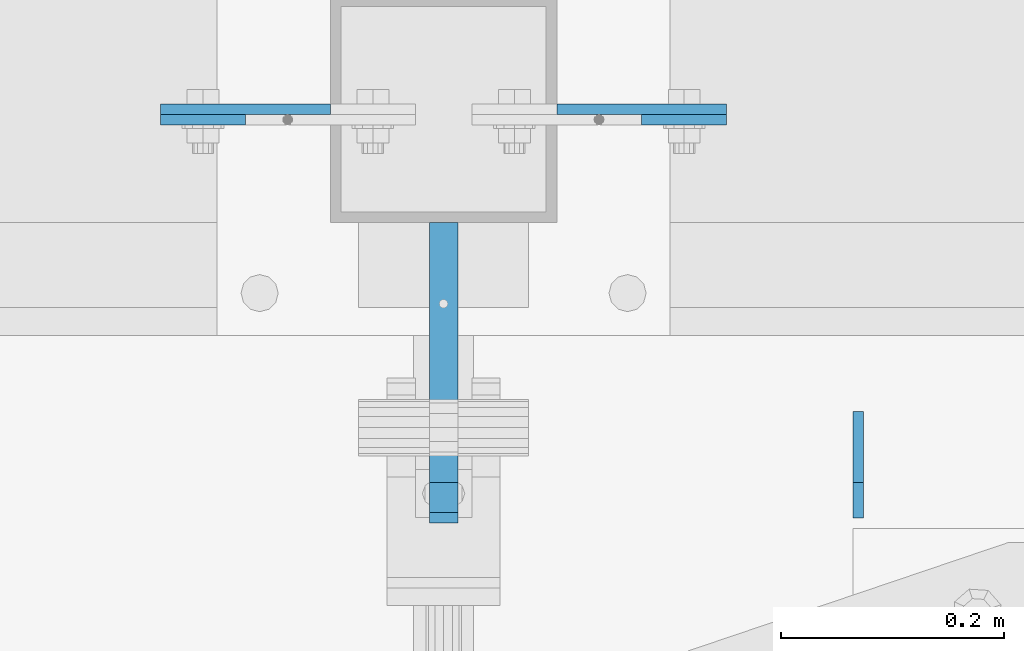
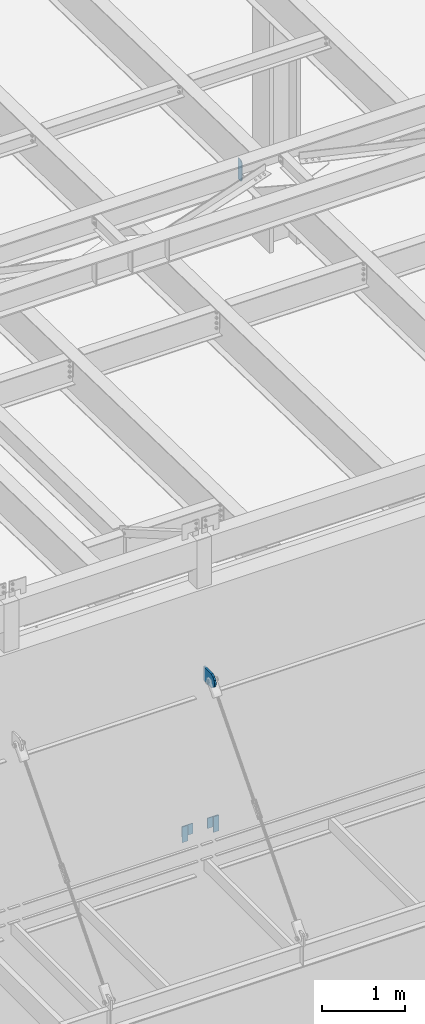
# One storey, part 1455 of 1763: 6 plates, 4 elements without a shape of their own.
"""IFC2X3 building model written with IfcOpenShell, lengths in millimetres."""

from ifc_helpers import new_model, si_unit, frame, origin_with_axes, place, context, subcontext, project, spatial, faceted_brep, material, type_object, element, aggregate, save


model = new_model("IFC2X3")

# Units and contexts
model_context = context("Model", 3, precision=1e-05, world=origin_with_axes())
body_context = subcontext(model_context, "Body", "Model", "MODEL_VIEW")
ifc_project = project(units=[si_unit("LENGTHUNIT", "METRE", prefix="MILLI"), si_unit("AREAUNIT", "SQUARE_METRE"), si_unit("VOLUMEUNIT", "CUBIC_METRE"), si_unit("MASSUNIT", "GRAM", prefix="KILO"), si_unit("TIMEUNIT", "SECOND"), si_unit("PLANEANGLEUNIT", "RADIAN"), si_unit("SOLIDANGLEUNIT", "STERADIAN"), si_unit("THERMODYNAMICTEMPERATUREUNIT", "DEGREE_CELSIUS"), si_unit("LUMINOUSINTENSITYUNIT", "LUMEN")], contexts=[model_context])

# Site, building, storey
site_placement = place(None, origin_with_axes())
site = spatial("IfcSite", under=ifc_project, at=site_placement, CompositionType="ELEMENT")
building_placement = place(site_placement, origin_with_axes())
building = spatial("IfcBuilding", under=site, at=building_placement, Name="Undefined", CompositionType="ELEMENT")
storey_placement = place(building_placement, origin_with_axes())
storey = spatial("IfcBuildingStorey", under=building, at=storey_placement, Name="Undefined", CompositionType="ELEMENT", Elevation=0.0)

# Assembly, plate
assembly_1_placement = place(storey_placement, origin_with_axes())
assembly_1 = element("IfcElementAssembly", 1, at=assembly_1_placement, inside=storey, Name="BEAM", AssemblyPlace="NOTDEFINED", PredefinedType="RIGID_FRAME")
ifc_material = material(Name="STEEL/A36")
plate_type_1 = type_object("IfcPlateType", PredefinedType="NOTDEFINED")
plate_1_placement = place(assembly_1_placement, frame((-59105.2270217928, -14217.6526242058, 8839.2), z_axis=(0.0, 0.0, 1.0), x_axis=(-1.0, 0.0, 0.0)))
plate_1 = element("IfcPlate", 2, at=plate_1_placement, type_object=plate_type_1, material=ifc_material, Name="PLATE", context=body_context, shape_type="Brep", body=[
    faceted_brep([(0.0, -4.76249999999982, 0.0), (-2.83762346953154e-10, -4.7624999996915, 228.600006103516), (-2.83762346953154e-10, 4.76250000028813, 228.600006103517), (0.0, 4.76249999999982, 0.0), (76.1999969480166, -4.76249999961874, 228.600006103516), (76.1999969480166, 4.76250000036089, 228.600006103517), (76.1999969482931, -4.76249999991705, 0.0), (76.1999969482931, 4.76250000006257, 1.81898940354586e-12)], [[[0, 1, 2, 3]], [[1, 4, 5, 2]], [[4, 6, 7, 5]], [[6, 0, 3, 7]], [[5, 7, 3, 2]], [[6, 4, 1, 0]]]),
])
aggregate(assembly_1, [plate_1])

assembly_2_placement = place(storey_placement, origin_with_axes())
assembly_2 = element("IfcElementAssembly", 3, at=assembly_2_placement, inside=storey, Name="BEAM", AssemblyPlace="NOTDEFINED", PredefinedType="RIGID_FRAME")
plate_2_placement = place(assembly_2_placement, frame((-58749.6269978255, -14217.652622428, 8839.2), z_axis=(0.0, 0.0, 1.0), x_axis=(1.0, 0.0, 0.0)))
plate_2 = element("IfcPlate", 4, at=plate_2_placement, type_object=plate_type_1, material=ifc_material, Name="PLATE", context=body_context, shape_type="Brep", body=[
    faceted_brep([(0.0, -4.76249999999982, 0.0), (-2.83762346953154e-10, -4.7624999996915, 228.600006103516), (-2.83762346953154e-10, 4.76250000028813, 228.600006103517), (0.0, 4.76249999999982, 0.0), (76.1999969480166, -4.76249999961874, 228.600006103516), (76.1999969480166, 4.76250000036089, 228.600006103517), (76.1999969482931, -4.76249999991705, 0.0), (76.1999969482931, 4.76250000006257, 1.81898940354586e-12)], [[[0, 1, 2, 3]], [[1, 4, 5, 2]], [[4, 6, 7, 5]], [[6, 0, 3, 7]], [[5, 7, 3, 2]], [[6, 4, 1, 0]]]),
])
aggregate(assembly_2, [plate_2])

# Assembly, plates
assembly_3_placement = place(storey_placement, origin_with_axes())
assembly_3 = element("IfcElementAssembly", 5, at=assembly_3_placement, inside=storey, Name="COLUMN", AssemblyPlace="NOTDEFINED", PredefinedType="RIGID_FRAME")
plate_type_2 = type_object("IfcPlateType", PredefinedType="NOTDEFINED")
plate_3_placement = place(assembly_3_placement, frame((-59181.4270187887, -14208.1276257052, 9067.80000610352), z_axis=(0.0, 0.0, -1.0), x_axis=(1.0, 0.0, 0.0)))
plate_3 = element("IfcPlate", 6, at=plate_3_placement, type_object=plate_type_2, material=ifc_material, Name="PLATE", context=body_context, shape_type="Brep", body=[
    faceted_brep([(0.0, -4.76249999999982, 0.0), (-3.05175672110636e-06, -4.7625000002663, 152.399993896484), (-3.05175490211695e-06, 4.76249999972788, 152.399993896484), (0.0, 4.76249999999982, 0.0), (152.400009155272, -4.76249999975698, 152.399993896484), (152.400009155273, 4.76250000024447, 152.399993896484), (152.400009155272, -4.76249999948777, 5.45696821063757e-12), (152.400009155273, 4.76250000051368, 3.63797880709171e-12)], [[[0, 1, 2, 3]], [[1, 4, 5, 2]], [[4, 6, 7, 5]], [[6, 0, 3, 7]], [[5, 7, 3, 2]], [[6, 4, 1, 0]]]),
])
plate_4_placement = place(assembly_3_placement, frame((-58673.4270009248, -14208.1276231655, 9067.80000610352), z_axis=(0.0, 0.0, -1.0), x_axis=(-1.0, 0.0, 0.0)))
plate_4 = element("IfcPlate", 7, at=plate_4_placement, type_object=plate_type_2, material=ifc_material, Name="PLATE", context=body_context, shape_type="Brep", body=[
    faceted_brep([(0.0, -4.76249999999982, 0.0), (-3.05175672110636e-06, -4.7625000002663, 152.399993896484), (-3.05175490211695e-06, 4.76249999972788, 152.399993896484), (0.0, 4.76249999999982, 0.0), (152.400009155272, -4.76249999975698, 152.399993896484), (152.400009155273, 4.76250000024447, 152.399993896484), (152.400009155272, -4.76249999948777, 5.45696821063757e-12), (152.400009155273, 4.76250000051368, 3.63797880709171e-12)], [[[0, 1, 2, 3]], [[1, 4, 5, 2]], [[4, 6, 7, 5]], [[6, 0, 3, 7]], [[5, 7, 3, 2]], [[6, 4, 1, 0]]]),
])
plate_type_3 = type_object("IfcPlateType", PredefinedType="NOTDEFINED")
plate_5_placement = place(assembly_3_placement, frame((-58927.4270098567, -14503.4026217954, 11188.7000003081), z_axis=(0.0, 0.0, 1.0), x_axis=(0.0, 1.0, 0.0)))
plate_5 = element("IfcPlate", 8, at=plate_5_placement, type_object=plate_type_3, material=ifc_material, Name="PLATE", context=body_context, shape_type="Brep", body=[
    faceted_brep([(0.0, -12.6999999999971, -1.81898940354586e-12), (-39.5764506670585, -12.6999999999971, 21.5331529121049), (-39.5764506670585, 12.6999999999971, 21.5331529121049), (0.0, 12.6999999999971, -1.81898940354586e-12), (-66.6095773920388, -12.6999999999971, 57.5773227764421), (-66.6095773920388, 12.6999999999971, 57.5773227764421), (-76.199996948335, -12.6999999999971, 101.599998461508), (-76.199996948335, 12.6999999999971, 101.599998461508), (-66.6095774066125, -12.6999999999971, 145.622674149748), (-66.6095774066125, 12.6999999999971, 145.622674149748), (-39.5764506935648, -12.6999999999971, 181.666844023039), (-39.5764506935648, 12.6999999999971, 181.666844023039), (-3.36349330609664e-08, -12.6999999999971, 203.199996948242), (-3.36349330609664e-08, 12.6999999999971, 203.199996948242), (193.675003051578, -12.6999999999971, 203.199996948413), (193.675003051578, 12.6999999999971, 203.199996948413), (193.675003051758, -12.6999999999971, 3.09228198602796e-10), (193.675003051758, 12.6999999999971, 3.09228198602796e-10)], [[[0, 1, 2, 3]], [[1, 4, 5, 2]], [[4, 6, 7, 5]], [[6, 8, 9, 7]], [[8, 10, 11, 9]], [[10, 12, 13, 11]], [[12, 14, 15, 13]], [[14, 16, 17, 15]], [[16, 0, 3, 17]], [[5, 7, 9, 11, 13, 15, 17, 3, 2]], [[16, 14, 12, 10, 8, 6, 4, 1, 0]]]),
])
aggregate(assembly_3, [plate_3, plate_4, plate_5])

# Assembly, plate
assembly_4_placement = place(storey_placement, origin_with_axes())
assembly_4 = element("IfcElementAssembly", 9, at=assembly_4_placement, inside=storey, Name="BEAM", AssemblyPlace="NOTDEFINED", PredefinedType="RIGID_FRAME")
plate_type_4 = type_object("IfcPlateType", PredefinedType="NOTDEFINED")
plate_6_placement = place(assembly_4_placement, frame((-58555.4238004347, -14574.8397438773, 18488.025), z_axis=(0.0, 0.0, 1.0), x_axis=(0.0, 1.0, 0.0)))
plate_6 = element("IfcPlate", 10, at=plate_6_placement, type_object=plate_type_4, material=ifc_material, Name="PLATE", context=body_context, shape_type="Brep", body=[
    faceted_brep([(0.0, -4.76250000000073, 31.75), (-3.63797880709171e-12, -4.76249999999709, 282.575012207031), (3.63797880709171e-12, 4.76249999999709, 282.575012207031), (0.0, 4.76250000000073, 31.75), (31.7499999999964, -4.7625000000844, 314.325012207031), (31.7500000000036, 4.76249999991705, 314.325012207031), (95.2499999999964, -4.76250000025902, 314.325012207031), (95.2500000000036, 4.76249999974243, 314.325012207031), (95.2499999999964, -4.76250000025902, 0.0), (95.2500000000036, 4.76249999974243, 0.0), (31.75, -4.76250000000073, 0.0), (31.75, 4.76250000000073, 0.0)], [[[0, 1, 2, 3]], [[1, 4, 5, 2]], [[4, 6, 7, 5]], [[6, 8, 9, 7]], [[8, 10, 11, 9]], [[10, 0, 3, 11]], [[5, 7, 9, 11, 3, 2]], [[10, 8, 6, 4, 1, 0]]]),
])
aggregate(assembly_4, [plate_6])

save(model, "model.ifc")
